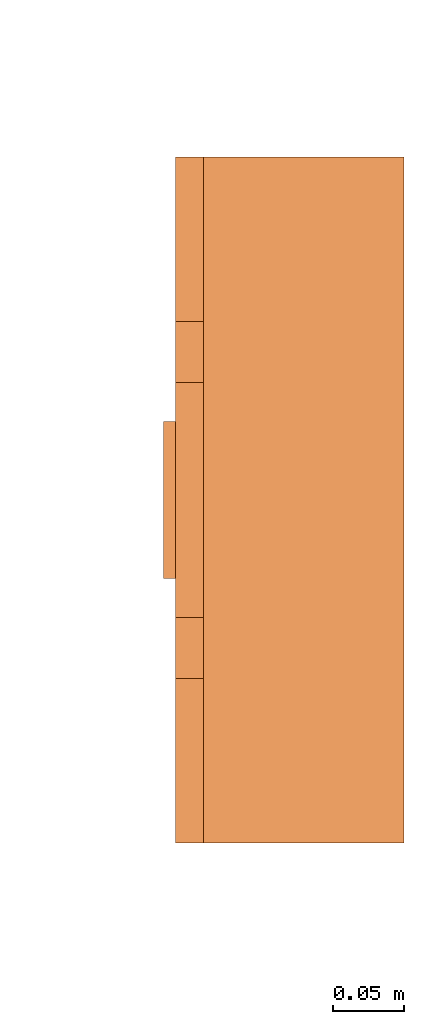
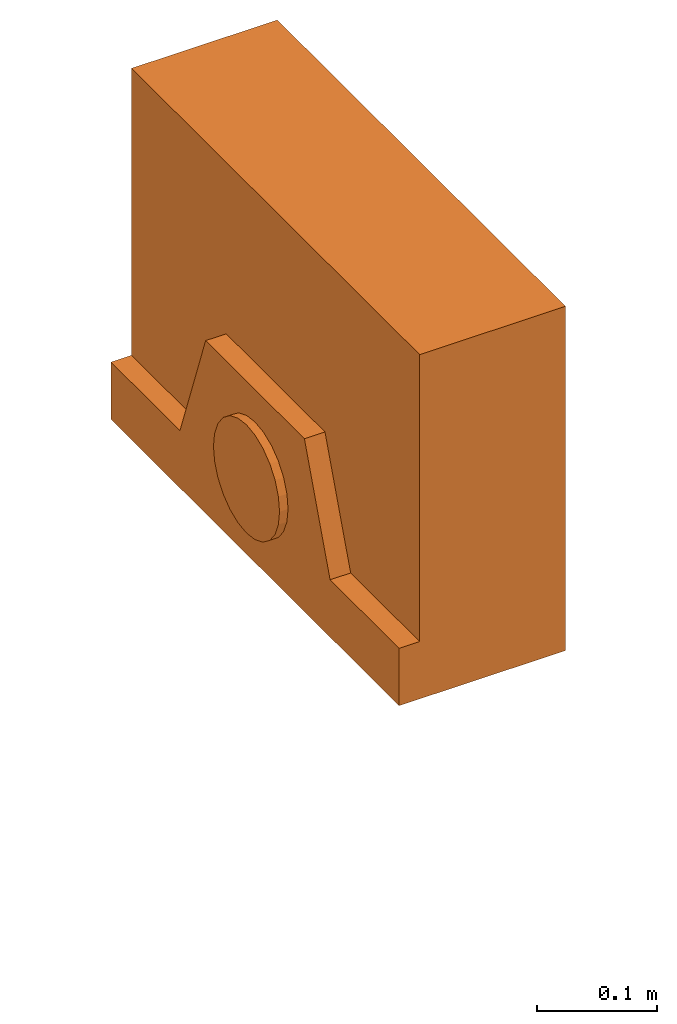
# One storey, part 4 of 4: 1 proxy.
"""IFC2X3 building model written with IfcOpenShell, lengths in millimetres."""

from ifc_helpers import new_model, entity, si_unit, converted_unit, derived_unit, direction, frame, origin, place, context, subcontext, project, spatial, faceted_brep, source, transform, mapped, material, material_list, type_object, type_shapes, element, save


model = new_model("IFC2X3")

# Units and contexts
model_context = context("Model", 3, precision=0.01, world=origin(), true_north=direction((6.12303176911189e-17, 1.0)))
body_context = subcontext(model_context, "Body", "Model", "MODEL_VIEW")
ifc_project = project(units=[si_unit("LENGTHUNIT", "METRE", prefix="MILLI"), si_unit("AREAUNIT", "SQUARE_METRE"), si_unit("VOLUMEUNIT", "CUBIC_METRE"), converted_unit("PLANEANGLEUNIT", "DEGREE", entity("IfcRatioMeasure", 0.0174532925199433), si_unit("PLANEANGLEUNIT", "RADIAN"), dimensions=[0, 0, 0, 0, 0, 0, 0]), si_unit("MASSUNIT", "GRAM", prefix="KILO"), derived_unit("MASSDENSITYUNIT", [(si_unit("MASSUNIT", "GRAM", prefix="KILO"), 1), (si_unit("LENGTHUNIT", "METRE"), -3)]), derived_unit("MOMENTOFINERTIAUNIT", [(si_unit("LENGTHUNIT", "METRE"), 4)]), si_unit("TIMEUNIT", "SECOND"), si_unit("FREQUENCYUNIT", "HERTZ"), si_unit("THERMODYNAMICTEMPERATUREUNIT", "DEGREE_CELSIUS"), derived_unit("THERMALTRANSMITTANCEUNIT", [(si_unit("MASSUNIT", "GRAM", prefix="KILO"), 1), (si_unit("THERMODYNAMICTEMPERATUREUNIT", "KELVIN"), -1), (si_unit("TIMEUNIT", "SECOND"), -3)]), derived_unit("VOLUMETRICFLOWRATEUNIT", [(si_unit("LENGTHUNIT", "METRE"), 3), (si_unit("TIMEUNIT", "SECOND"), -1)]), derived_unit("MASSFLOWRATEUNIT", [(si_unit("MASSUNIT", "GRAM", prefix="KILO"), 1), (si_unit("TIMEUNIT", "SECOND"), -1)]), derived_unit("ROTATIONALFREQUENCYUNIT", [(si_unit("TIMEUNIT", "SECOND"), -1)]), si_unit("ELECTRICCURRENTUNIT", "AMPERE"), si_unit("ELECTRICVOLTAGEUNIT", "VOLT"), si_unit("POWERUNIT", "WATT"), si_unit("FORCEUNIT", "NEWTON", prefix="KILO"), si_unit("ILLUMINANCEUNIT", "LUX"), si_unit("LUMINOUSFLUXUNIT", "LUMEN"), si_unit("LUMINOUSINTENSITYUNIT", "CANDELA"), derived_unit("USERDEFINED", [(si_unit("MASSUNIT", "GRAM", prefix="KILO"), -1), (si_unit("LENGTHUNIT", "METRE"), -2), (si_unit("TIMEUNIT", "SECOND"), 3), (si_unit("LUMINOUSFLUXUNIT", "LUMEN"), 1)]), derived_unit("LINEARVELOCITYUNIT", [(si_unit("LENGTHUNIT", "METRE"), 1), (si_unit("TIMEUNIT", "SECOND"), -1)]), si_unit("PRESSUREUNIT", "PASCAL"), derived_unit("USERDEFINED", [(si_unit("LENGTHUNIT", "METRE"), -2), (si_unit("MASSUNIT", "GRAM", prefix="KILO"), 1), (si_unit("TIMEUNIT", "SECOND"), -2)]), derived_unit("LINEARFORCEUNIT", [(si_unit("MASSUNIT", "GRAM", prefix="KILO"), 1), (si_unit("LENGTHUNIT", "METRE"), 1), (si_unit("TIMEUNIT", "SECOND"), -2), (si_unit("LENGTHUNIT", "METRE"), -1)]), derived_unit("PLANARFORCEUNIT", [(si_unit("MASSUNIT", "GRAM", prefix="KILO"), 1), (si_unit("LENGTHUNIT", "METRE"), 1), (si_unit("TIMEUNIT", "SECOND"), -2), (si_unit("LENGTHUNIT", "METRE"), -2)])], contexts=[model_context])

# Site, building, storey
site_placement = place(None, frame((0.0, 2493.83037508239, 0.0)))
site = spatial("IfcSite", under=ifc_project, at=site_placement, CompositionType="ELEMENT")
building_placement = place(site_placement, origin())
building = spatial("IfcBuilding", under=site, at=building_placement, CompositionType="ELEMENT")
storey_placement = place(building_placement, frame((0.0, 0.0, 15900.0)))
storey = spatial("IfcBuildingStorey", under=building, at=storey_placement, Name="05", CompositionType="ELEMENT", Elevation=15900.0)

# Proxy
ifc_material_1 = material()
ifc_material_2 = material()
ifc_material_list = material_list([ifc_material_1, ifc_material_2])
building_element_proxy_type = type_object("IfcBuildingElementProxyType", PredefinedType="NOTDEFINED", material=ifc_material_1)
shared_shape = source(origin(), body_context, "Body", "Brep", [
    faceted_brep([(168.201612490282, 212.500000000001, 135.54049916809), (168.201612490282, 201.109127034741, 126.799974925206), (168.201612490282, 192.368602791857, 115.409101959946), (168.201612490282, 186.874079554102, 102.144149440585), (168.201612490282, 185.0, 87.9091019599461), (168.201612490282, 186.874079554102, 73.6740544793074), (168.201612490282, 192.368602791856, 60.4091019599461), (168.201612490282, 201.10912703474, 49.0182289946861), (168.201612490282, 212.500000000001, 40.2777047518019), (168.201612490282, 225.764952519362, 34.7831815140474), (168.201612490282, 240.0, 32.9091019599461), (168.201612490282, 254.235047480639, 34.7831815140472), (168.201612490282, 267.5, 40.2777047518019), (168.201612490282, 278.890872965261, 49.0182289946858), (168.201612490282, 287.631397208145, 60.4091019599458), (168.201612490282, 293.125920445899, 73.6740544793071), (168.201612490282, 295.0, 87.9091019599458), (168.201612490282, 293.125920445899, 102.144149440584), (168.201612490282, 287.631397208145, 115.409101959946), (168.201612490282, 278.890872965261, 126.799974925206), (168.201612490282, 267.500000000001, 135.54049916809), (168.201612490282, 254.235047480639, 141.035022405845), (168.201612490282, 240.0, 142.909101959946), (168.201612490282, 225.764952519362, 141.035022405845), (160.0, 225.764952519362, 34.7831815140474), (160.0, 212.500000000001, 40.2777047518019), (160.0, 201.10912703474, 49.0182289946861), (160.0, 192.368602791856, 60.4091019599461), (160.0, 186.874079554102, 73.6740544793074), (160.0, 185.0, 87.9091019599463), (160.0, 186.874079554102, 102.144149440585), (160.0, 192.368602791857, 115.409101959946), (160.0, 201.109127034741, 126.799974925206), (160.0, 212.500000000001, 135.54049916809), (160.0, 225.764952519362, 141.035022405845), (160.0, 240.0, 142.909101959946), (160.0, 254.235047480639, 141.035022405845), (160.0, 267.500000000001, 135.54049916809), (160.0, 278.890872965261, 126.799974925206), (160.0, 287.631397208145, 115.409101959946), (160.0, 293.125920445899, 102.144149440584), (160.0, 295.0, 87.9091019599458), (160.0, 293.125920445899, 73.6740544793071), (160.0, 287.631397208145, 60.4091019599458), (160.0, 278.890872965261, 49.0182289946858), (160.0, 267.5, 40.2777047518019), (160.0, 254.235047480639, 34.7831815140472), (160.0, 240.0, 32.9091019599461)], [[[0, 1, 2, 3, 4, 5, 6, 7, 8, 9, 10, 11, 12, 13, 14, 15, 16, 17, 18, 19, 20, 21, 22, 23]], [[24, 25, 26, 27, 28, 29, 30, 31, 32, 33, 34, 35, 36, 37, 38, 39, 40, 41, 42, 43, 44, 45, 46, 47]], [[40, 17, 16, 41]], [[39, 18, 17, 40]], [[20, 19, 38, 37]], [[39, 38, 19, 18]], [[21, 20, 37, 36]], [[22, 21, 36, 35]], [[34, 23, 22, 35]], [[33, 0, 23, 34]], [[2, 1, 32, 31]], [[33, 32, 1, 0]], [[3, 2, 31, 30]], [[4, 3, 30, 29]], [[28, 5, 4, 29]], [[27, 6, 5, 28]], [[8, 7, 26, 25]], [[27, 26, 7, 6]], [[9, 8, 25, 24]], [[10, 9, 24, 47]], [[46, 11, 10, 47]], [[45, 12, 11, 46]], [[14, 13, 44, 43]], [[45, 44, 13, 12]], [[15, 14, 43, 42]], [[16, 15, 42, 41]]]),
    faceted_brep([(160.0, 0.0, 0.0), (160.0, 480.0, 0.0), (160.0, 480.0, 58.2870579365997), (160.0, 365.0, 58.2870579366005), (160.0, 322.247482084292, 175.748635534839), (160.0, 157.75251791571, 175.748635534839), (160.0, 115.0, 58.2870579366), (160.0, 0.0, 58.2870579365997), (0.0, 480.0, 0.0), (0.0, 0.0, 0.0), (0.0, 0.0, 350.0), (0.0, 480.0, 350.0), (140.211167148102, 480.0, 350.0), (140.211167148102, 480.0, 58.2870579365997), (140.211167148102, 0.0, 350.0), (140.211167148102, 0.0, 58.2870579365997), (140.211167148102, 365.0, 58.2870579366), (140.211167148102, 115.0, 58.2870579366), (140.211167148102, 157.75251791571, 175.748635534839), (140.211167148102, 322.247482084292, 175.748635534839)], [[[0, 1, 2, 3, 4, 5, 6, 7]], [[8, 9, 10, 11]], [[8, 11, 12, 13, 2, 1]], [[11, 10, 14, 12]], [[10, 9, 0, 7, 15, 14]], [[1, 0, 9, 8]], [[16, 13, 12, 14, 15, 17, 18, 19]], [[13, 16, 3, 2]], [[17, 15, 7, 6]], [[18, 17, 6, 5]], [[19, 18, 5, 4]], [[16, 19, 4, 3]]]),
])
type_shapes(building_element_proxy_type, [shared_shape])
proxy_placement = place(storey_placement, frame((65229.9998291021, 15708.0573271193, 1500.0), z_axis=(0.0, 0.0, 1.0), x_axis=(-1.0, 0.0, 0.0)))
element("IfcBuildingElementProxy", 1, at=proxy_placement, inside=storey, type_object=building_element_proxy_type, material=ifc_material_list, context=body_context, shape_type="MappedRepresentation", body=[
    mapped(shared_shape, transform((0.0, 0.0, 0.0), scale=1.0)),
])

save(model, "model.ifc")
